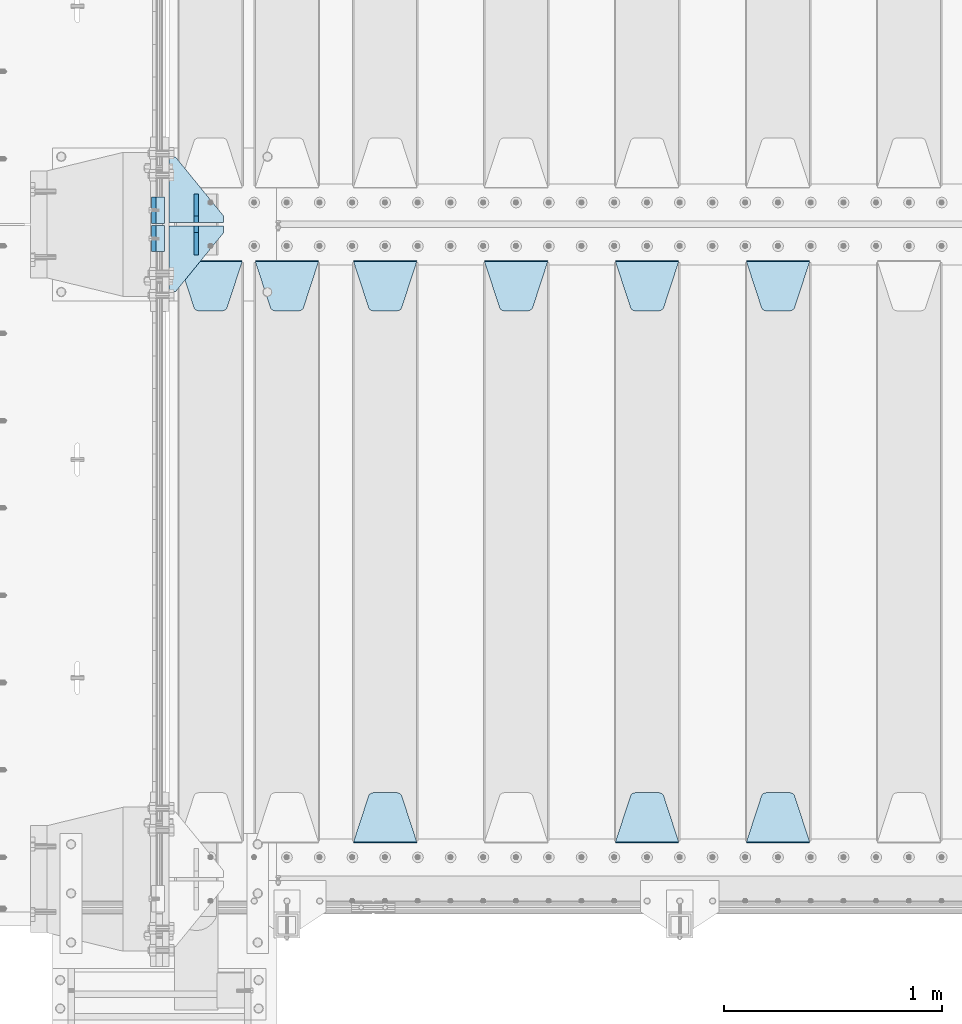
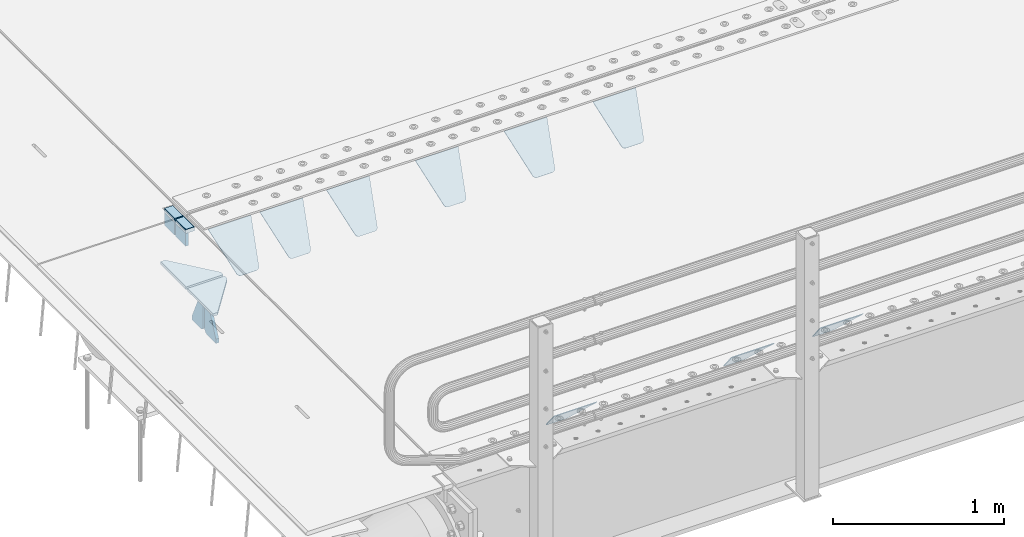
# One storey, part 175 of 219: 17 plates.
"""IFC2X3 building model written with IfcOpenShell, lengths in millimetres."""

from ifc_helpers import new_model, si_unit, frame, origin_with_axes, place, context, subcontext, project, spatial, faceted_brep, material, type_object, element, save


model = new_model("IFC2X3")

# Units and contexts
model_context = context("Model", 3, precision=1e-05, world=origin_with_axes())
body_context = subcontext(model_context, "Body", "Model", "MODEL_VIEW")
ifc_project = project(units=[si_unit("LENGTHUNIT", "METRE", prefix="MILLI"), si_unit("AREAUNIT", "SQUARE_METRE"), si_unit("VOLUMEUNIT", "CUBIC_METRE"), si_unit("MASSUNIT", "GRAM", prefix="KILO"), si_unit("TIMEUNIT", "SECOND"), si_unit("PLANEANGLEUNIT", "RADIAN"), si_unit("SOLIDANGLEUNIT", "STERADIAN"), si_unit("THERMODYNAMICTEMPERATUREUNIT", "DEGREE_CELSIUS"), si_unit("LUMINOUSINTENSITYUNIT", "LUMEN")], contexts=[model_context])

# Site, building, storey
site_placement = place(None, origin_with_axes())
site = spatial("IfcSite", under=ifc_project, at=site_placement, CompositionType="ELEMENT")
building_placement = place(site_placement, origin_with_axes())
building = spatial("IfcBuilding", under=site, at=building_placement, Name="Standard", CompositionType="ELEMENT")
storey_placement = place(building_placement, origin_with_axes())
storey = spatial("IfcBuildingStorey", under=building, at=storey_placement, Name="Undefined", CompositionType="ELEMENT", Elevation=0.0)

# Plates
ifc_material_1 = material()
plate_type_1 = type_object("IfcPlateType", PredefinedType="NOTDEFINED")
plate_1_placement = place(storey_placement, frame((-10.000000000067, 26935.0000000001, -16.0000945328547), z_axis=(-1.0, 0.0, 0.0), x_axis=(0.0, 0.0, 1.0)))
element("IfcPlate", 1, at=plate_1_placement, inside=storey, type_object=plate_type_1, material=ifc_material_1, context=body_context, shape_type="Brep", body=[
    faceted_brep([(0.0, -60.0, 0.0), (2.49929144047201e-09, -60.0, 60.0), (2.49929144047201e-09, 60.0000000000036, 60.0), (0.0, 60.0000000000036, 0.0), (25.0146748218828, -60.0, 60.0), (25.0146748218828, 60.0, 60.0), (26.5597449794466, -60.0, 59.7552873949117), (26.5597449794466, 60.0000000000036, 59.7552873949117), (27.9535758796897, -59.9999999999964, 59.0451032832824), (27.9535758796897, 60.0000000000036, 59.0451032832824), (29.0597323263517, -60.0, 57.9389640667317), (29.0597323263517, 60.0, 57.9389640667317), (29.7699381491534, -59.9999999999964, 56.5451442289687), (29.7699381491534, 60.0, 56.5451442289687), (30.0146748212763, -60.0, 55.0000778834025), (30.0146748212762, 60.0, 55.0000778834025), (30.0154536553013, -59.9999999999964, 5.00007788340855), (30.0154536553013, 60.0000000000036, 5.00007788340855), (29.7707554908505, -60.0, 3.45497428546548), (29.7707554908505, 60.0, 3.45497428546548), (29.0605660948355, -60.0, 2.06111154407017), (29.0605660948355, 60.0, 2.06111154407017), (27.9544051209123, -59.9999999999964, 0.954933339696428), (27.9544051209123, 60.0000000000036, 0.954933339696428), (26.5605534420796, -59.9999999999964, 0.244722232012666), (26.5605534420796, 60.0000000000036, 0.244722232012666), (25.0154536559091, -60.0, 6.05382410867605e-12), (25.0154536559091, 60.0, 6.05382410867605e-12)], [[[0, 1, 2, 3]], [[1, 4, 5, 2]], [[4, 6, 7, 5]], [[6, 8, 9, 7]], [[8, 10, 11, 9]], [[10, 12, 13, 11]], [[12, 14, 15, 13]], [[14, 16, 17, 15]], [[16, 18, 19, 17]], [[18, 20, 21, 19]], [[20, 22, 23, 21]], [[22, 24, 25, 23]], [[24, 26, 27, 25]], [[26, 0, 3, 27]], [[5, 7, 9, 11, 13, 15, 17, 19, 21, 23, 25, 27, 3, 2]], [[26, 24, 22, 20, 18, 16, 14, 12, 10, 8, 6, 4, 1, 0]]]),
])
plate_2_placement = place(storey_placement, frame((-10.0000000600267, 27065.0000004521, -16.0145962164398), z_axis=(-1.0, 0.0, 0.0), x_axis=(0.0, -4.95099997756316e-06, 0.999999999987744)))
element("IfcPlate", 2, at=plate_2_placement, inside=storey, type_object=plate_type_1, material=ifc_material_1, context=body_context, shape_type="Brep", body=[
    faceted_brep([(0.0, -60.0, 0.0), (-0.000933120085687023, -60.0000000000036, 60.0), (-0.000933120085687023, 59.9999999999964, 60.0), (0.0, 60.0000000000036, 0.0), (24.9991450303709, -60.0, 60.0), (24.9991450303709, 59.9999999999964, 60.0), (26.544215218168, -60.0000000000036, 59.7552873850884), (26.544215218168, 60.0, 59.7552873850884), (27.9380461396139, -60.0000000000036, 59.0451032459123), (27.9380461396139, 60.0, 59.0451032459123), (29.0442025908961, -60.0000000000036, 57.9389639895784), (29.0442025908961, 60.0, 57.9389639895784), (29.7544083969366, -60.0, 56.5451441080361), (29.7544083969366, 60.0000000000036, 56.5451441080361), (29.9991450297669, -60.0000000000036, 55.0000777244568), (29.9991450297669, 60.0, 55.0000777244568), (29.999922274335, -60.0, 5.00007772445704), (29.999922274335, 60.0, 5.00007772445704), (29.7552240705896, -60.0000000000036, 3.45497416452589), (29.7552240705896, 60.0, 3.45497416452589), (29.0450346578116, -60.0, 2.06111146690959), (29.0450346578116, 59.9999999999964, 2.06111146690959), (27.9388736885072, -60.0, 0.954933302319514), (27.9388736885072, 59.9999999999964, 0.954933302319514), (26.5450220308766, -60.0000000000036, 0.244722222183089), (26.5450220308766, 60.0, 0.244722222183089), (24.9999222749392, -60.0, 2.64677169070637e-13), (24.9999222749392, 60.0, 2.66453525910038e-13)], [[[0, 1, 2, 3]], [[1, 4, 5, 2]], [[4, 6, 7, 5]], [[6, 8, 9, 7]], [[8, 10, 11, 9]], [[10, 12, 13, 11]], [[12, 14, 15, 13]], [[14, 16, 17, 15]], [[16, 18, 19, 17]], [[18, 20, 21, 19]], [[20, 22, 23, 21]], [[22, 24, 25, 23]], [[24, 26, 27, 25]], [[26, 0, 3, 27]], [[5, 7, 9, 11, 13, 15, 17, 19, 21, 23, 25, 27, 3, 2]], [[26, 24, 22, 20, 18, 16, 14, 12, 10, 8, 6, 4, 1, 0]]]),
])
ifc_material_2 = material(Name="STEEL/S355N")
plate_type_2 = type_object("IfcPlateType", PredefinedType="NOTDEFINED")
plate_3_placement = place(storey_placement, frame((-60.0000000000706, 26995.0000855345, -105.984429072951), z_axis=(0.0, -1.0, 0.0), x_axis=(0.0, 0.0, 1.0)))
element("IfcPlate", 3, at=plate_3_placement, inside=storey, type_object=plate_type_2, material=ifc_material_2, context=body_context, shape_type="Brep", body=[
    faceted_brep([(0.0, -10.0, 0.0), (4.30816271546064e-10, -10.0, 120.000000000004), (4.30816271546064e-10, 10.0, 120.000000000004), (0.0, 10.0, 0.0), (89.9845046997066, -10.0, 120.0), (89.9845046997066, 10.0, 120.0), (89.9843902587891, -10.0, 6.18456397205591e-11), (89.9843902587891, 10.0, 6.18456397205591e-11)], [[[0, 1, 2, 3]], [[1, 4, 5, 2]], [[4, 6, 7, 5]], [[6, 0, 3, 7]], [[5, 7, 3, 2]], [[6, 4, 1, 0]]]),
])
plate_4_placement = place(storey_placement, frame((-60.0, 27125.000446002, -106.014921246643), z_axis=(0.0, -0.999999999987744, -4.95099999993769e-06), x_axis=(0.0, -4.95099997756316e-06, 0.999999999987744)))
element("IfcPlate", 4, at=plate_4_placement, inside=storey, type_object=plate_type_2, material=ifc_material_2, context=body_context, shape_type="Brep", body=[
    faceted_brep([(0.0, -10.0, 0.0), (4.30816271546064e-10, -10.0, 120.000000000004), (4.30816271546064e-10, 10.0, 120.000000000004), (0.0, 10.0, 0.0), (89.9999999999979, -10.0, 120.000000000004), (89.9999999999979, 10.0, 120.000000000004), (90.0, -10.0, 1.09139364212751e-11), (90.0, 10.0, 1.09139364212751e-11)], [[[0, 1, 2, 3]], [[1, 4, 5, 2]], [[4, 6, 7, 5]], [[6, 0, 3, 7]], [[5, 7, 3, 2]], [[6, 4, 1, 0]]]),
])
plate_type_3 = type_object("IfcPlateType", PredefinedType="NOTDEFINED")
plate_5_placement = place(storey_placement, frame((2655.0, 26831.767766956, -1.76776695296758), z_axis=(0.0, -0.707106781186547, -0.707106781186548), x_axis=(1.0, 0.0, 0.0)))
element("IfcPlate", 5, at=plate_5_placement, inside=storey, type_object=plate_type_3, material=ifc_material_2, context=body_context, shape_type="Brep", body=[
    faceted_brep([(0.0, -2.5, 0.0), (69.345504679477, -2.5, 300.171731424834), (69.345504679477, 2.49999999999636, 300.171731424831), (0.0, 2.5, 0.0), (70.9274061199576, -2.50000000000364, 304.8974424154), (70.9274061199576, 2.49999999999636, 304.8974424154), (73.3818627772307, -2.50000000000364, 309.234538108532), (73.3818627772307, 2.49999999999636, 309.234538108532), (76.6187032999569, -2.50000000000364, 313.023683126106), (76.6187032999569, 2.49999999999636, 313.023683126106), (80.5190132704993, -2.50000000000364, 316.125672595372), (80.5190132704993, 2.49999999999636, 316.125672595372), (84.9395038596831, -2.50000000000364, 318.426546230476), (84.9395038596831, 2.5, 318.426546230479), (89.7177759439237, -2.50000000000364, 319.841774983277), (89.7177759439237, 2.5, 319.841774983281), (94.6782862926502, -2.50000000000364, 320.319366455078), (94.6782862926502, 2.49999999999636, 320.319366455078), (195.32171370735, -2.50000000000364, 320.319366455078), (195.32171370735, 2.49999999999636, 320.319366455078), (200.282224056076, -2.50000000000364, 319.841774983277), (200.282224056076, 2.5, 319.841774983281), (205.060496140317, -2.50000000000364, 318.426546230476), (205.060496140317, 2.49999999999636, 318.426546230476), (209.480986729501, -2.50000000000364, 316.125672595372), (209.480986729501, 2.49999999999636, 316.125672595372), (213.381296700043, -2.50000000000364, 313.023683126106), (213.381296700043, 2.49999999999272, 313.023683126106), (216.618137222769, -2.50000000000364, 309.234538108529), (216.618137222769, 2.49999999999636, 309.234538108525), (219.072593880042, -2.50000000000364, 304.8974424154), (219.072593880042, 2.49999999999636, 304.8974424154), (220.654495320523, -2.5, 300.171731424834), (220.654495320523, 2.49999999999636, 300.171731424831), (290.0, -2.50000000000364, 3.63797880709171e-12), (290.0, 2.49999999999636, 0.0)], [[[0, 1, 2, 3]], [[1, 4, 5, 2]], [[4, 6, 7, 5]], [[6, 8, 9, 7]], [[8, 10, 11, 9]], [[10, 12, 13, 11]], [[12, 14, 15, 13]], [[14, 16, 17, 15]], [[16, 18, 19, 17]], [[18, 20, 21, 19]], [[20, 22, 23, 21]], [[22, 24, 25, 23]], [[24, 26, 27, 25]], [[26, 28, 29, 27]], [[28, 30, 31, 29]], [[30, 32, 33, 31]], [[32, 34, 35, 33]], [[34, 0, 3, 35]], [[5, 7, 9, 11, 13, 15, 17, 19, 21, 23, 25, 27, 29, 31, 33, 35, 3, 2]], [[34, 32, 30, 28, 26, 24, 22, 20, 18, 16, 14, 12, 10, 8, 6, 4, 1, 0]]]),
])
plate_6_placement = place(storey_placement, frame((2945.0, 24168.232233047, -1.76776695296758), z_axis=(0.0, 0.707106781186547, -0.707106781186548), x_axis=(-1.0, 0.0, 0.0)))
element("IfcPlate", 6, at=plate_6_placement, inside=storey, type_object=plate_type_3, material=ifc_material_2, context=body_context, shape_type="Brep", body=[
    faceted_brep([(0.0, -2.5, 0.0), (69.345504679477, -2.5, 300.171731424834), (69.345504679477, 2.49999999999636, 300.171731424831), (0.0, 2.5, 0.0), (70.9274061199576, -2.50000000000364, 304.8974424154), (70.9274061199576, 2.49999999999636, 304.8974424154), (73.3818627772307, -2.50000000000364, 309.234538108532), (73.3818627772307, 2.49999999999636, 309.234538108532), (76.6187032999569, -2.50000000000364, 313.023683126106), (76.6187032999569, 2.49999999999636, 313.023683126106), (80.5190132704993, -2.50000000000364, 316.125672595372), (80.5190132704993, 2.49999999999636, 316.125672595372), (84.9395038596831, -2.50000000000364, 318.426546230476), (84.9395038596831, 2.5, 318.426546230479), (89.7177759439237, -2.50000000000364, 319.841774983277), (89.7177759439237, 2.5, 319.841774983281), (94.6782862926502, -2.50000000000364, 320.319366455078), (94.6782862926502, 2.49999999999636, 320.319366455078), (195.32171370735, -2.50000000000364, 320.319366455078), (195.32171370735, 2.49999999999636, 320.319366455078), (200.282224056076, -2.50000000000364, 319.841774983277), (200.282224056076, 2.5, 319.841774983281), (205.060496140317, -2.50000000000364, 318.426546230476), (205.060496140317, 2.49999999999636, 318.426546230476), (209.480986729501, -2.50000000000364, 316.125672595372), (209.480986729501, 2.49999999999636, 316.125672595372), (213.381296700043, -2.50000000000364, 313.023683126106), (213.381296700043, 2.49999999999272, 313.023683126106), (216.618137222769, -2.50000000000364, 309.234538108529), (216.618137222769, 2.49999999999636, 309.234538108525), (219.072593880042, -2.50000000000364, 304.8974424154), (219.072593880042, 2.49999999999636, 304.8974424154), (220.654495320523, -2.5, 300.171731424834), (220.654495320523, 2.49999999999636, 300.171731424831), (290.0, -2.50000000000364, 3.63797880709171e-12), (290.0, 2.49999999999636, 0.0)], [[[0, 1, 2, 3]], [[1, 4, 5, 2]], [[4, 6, 7, 5]], [[6, 8, 9, 7]], [[8, 10, 11, 9]], [[10, 12, 13, 11]], [[12, 14, 15, 13]], [[14, 16, 17, 15]], [[16, 18, 19, 17]], [[18, 20, 21, 19]], [[20, 22, 23, 21]], [[22, 24, 25, 23]], [[24, 26, 27, 25]], [[26, 28, 29, 27]], [[28, 30, 31, 29]], [[30, 32, 33, 31]], [[32, 34, 35, 33]], [[34, 0, 3, 35]], [[5, 7, 9, 11, 13, 15, 17, 19, 21, 23, 25, 27, 29, 31, 33, 35, 3, 2]], [[34, 32, 30, 28, 26, 24, 22, 20, 18, 16, 14, 12, 10, 8, 6, 4, 1, 0]]]),
])
plate_7_placement = place(storey_placement, frame((2055.0, 26831.767766956, -1.76776695296758), z_axis=(0.0, -0.707106781186547, -0.707106781186548), x_axis=(1.0, 0.0, 0.0)))
element("IfcPlate", 7, at=plate_7_placement, inside=storey, type_object=plate_type_3, material=ifc_material_2, context=body_context, shape_type="Brep", body=[
    faceted_brep([(0.0, -2.5, 0.0), (69.345504679477, -2.5, 300.171731424834), (69.345504679477, 2.49999999999636, 300.171731424831), (0.0, 2.5, 0.0), (70.9274061199576, -2.50000000000364, 304.8974424154), (70.9274061199576, 2.49999999999636, 304.8974424154), (73.3818627772307, -2.50000000000364, 309.234538108532), (73.3818627772307, 2.49999999999636, 309.234538108532), (76.6187032999569, -2.50000000000364, 313.023683126106), (76.6187032999569, 2.49999999999636, 313.023683126106), (80.5190132704993, -2.50000000000364, 316.125672595372), (80.5190132704993, 2.49999999999636, 316.125672595372), (84.9395038596831, -2.50000000000364, 318.426546230476), (84.9395038596831, 2.5, 318.426546230479), (89.7177759439237, -2.50000000000364, 319.841774983277), (89.7177759439237, 2.5, 319.841774983281), (94.6782862926502, -2.50000000000364, 320.319366455078), (94.6782862926502, 2.49999999999636, 320.319366455078), (195.32171370735, -2.50000000000364, 320.319366455078), (195.32171370735, 2.49999999999636, 320.319366455078), (200.282224056076, -2.50000000000364, 319.841774983277), (200.282224056076, 2.5, 319.841774983281), (205.060496140317, -2.50000000000364, 318.426546230476), (205.060496140317, 2.49999999999636, 318.426546230476), (209.480986729501, -2.50000000000364, 316.125672595372), (209.480986729501, 2.49999999999636, 316.125672595372), (213.381296700043, -2.50000000000364, 313.023683126106), (213.381296700043, 2.49999999999272, 313.023683126106), (216.618137222769, -2.50000000000364, 309.234538108529), (216.618137222769, 2.49999999999636, 309.234538108525), (219.072593880042, -2.50000000000364, 304.8974424154), (219.072593880042, 2.49999999999636, 304.8974424154), (220.654495320523, -2.5, 300.171731424834), (220.654495320523, 2.49999999999636, 300.171731424831), (290.0, -2.50000000000364, 3.63797880709171e-12), (290.0, 2.49999999999636, 0.0)], [[[0, 1, 2, 3]], [[1, 4, 5, 2]], [[4, 6, 7, 5]], [[6, 8, 9, 7]], [[8, 10, 11, 9]], [[10, 12, 13, 11]], [[12, 14, 15, 13]], [[14, 16, 17, 15]], [[16, 18, 19, 17]], [[18, 20, 21, 19]], [[20, 22, 23, 21]], [[22, 24, 25, 23]], [[24, 26, 27, 25]], [[26, 28, 29, 27]], [[28, 30, 31, 29]], [[30, 32, 33, 31]], [[32, 34, 35, 33]], [[34, 0, 3, 35]], [[5, 7, 9, 11, 13, 15, 17, 19, 21, 23, 25, 27, 29, 31, 33, 35, 3, 2]], [[34, 32, 30, 28, 26, 24, 22, 20, 18, 16, 14, 12, 10, 8, 6, 4, 1, 0]]]),
])
plate_8_placement = place(storey_placement, frame((2345.0, 24168.232233047, -1.76776695296758), z_axis=(0.0, 0.707106781186547, -0.707106781186548), x_axis=(-1.0, 0.0, 0.0)))
element("IfcPlate", 8, at=plate_8_placement, inside=storey, type_object=plate_type_3, material=ifc_material_2, context=body_context, shape_type="Brep", body=[
    faceted_brep([(0.0, -2.5, 0.0), (69.345504679477, -2.5, 300.171731424834), (69.345504679477, 2.49999999999636, 300.171731424831), (0.0, 2.5, 0.0), (70.9274061199576, -2.50000000000364, 304.8974424154), (70.9274061199576, 2.49999999999636, 304.8974424154), (73.3818627772307, -2.50000000000364, 309.234538108532), (73.3818627772307, 2.49999999999636, 309.234538108532), (76.6187032999569, -2.50000000000364, 313.023683126106), (76.6187032999569, 2.49999999999636, 313.023683126106), (80.5190132704993, -2.50000000000364, 316.125672595372), (80.5190132704993, 2.49999999999636, 316.125672595372), (84.9395038596831, -2.50000000000364, 318.426546230476), (84.9395038596831, 2.5, 318.426546230479), (89.7177759439237, -2.50000000000364, 319.841774983277), (89.7177759439237, 2.5, 319.841774983281), (94.6782862926502, -2.50000000000364, 320.319366455078), (94.6782862926502, 2.49999999999636, 320.319366455078), (195.32171370735, -2.50000000000364, 320.319366455078), (195.32171370735, 2.49999999999636, 320.319366455078), (200.282224056076, -2.50000000000364, 319.841774983277), (200.282224056076, 2.5, 319.841774983281), (205.060496140317, -2.50000000000364, 318.426546230476), (205.060496140317, 2.49999999999636, 318.426546230476), (209.480986729501, -2.50000000000364, 316.125672595372), (209.480986729501, 2.49999999999636, 316.125672595372), (213.381296700043, -2.50000000000364, 313.023683126106), (213.381296700043, 2.49999999999272, 313.023683126106), (216.618137222769, -2.50000000000364, 309.234538108529), (216.618137222769, 2.49999999999636, 309.234538108525), (219.072593880042, -2.50000000000364, 304.8974424154), (219.072593880042, 2.49999999999636, 304.8974424154), (220.654495320523, -2.5, 300.171731424834), (220.654495320523, 2.49999999999636, 300.171731424831), (290.0, -2.50000000000364, 3.63797880709171e-12), (290.0, 2.49999999999636, 0.0)], [[[0, 1, 2, 3]], [[1, 4, 5, 2]], [[4, 6, 7, 5]], [[6, 8, 9, 7]], [[8, 10, 11, 9]], [[10, 12, 13, 11]], [[12, 14, 15, 13]], [[14, 16, 17, 15]], [[16, 18, 19, 17]], [[18, 20, 21, 19]], [[20, 22, 23, 21]], [[22, 24, 25, 23]], [[24, 26, 27, 25]], [[26, 28, 29, 27]], [[28, 30, 31, 29]], [[30, 32, 33, 31]], [[32, 34, 35, 33]], [[34, 0, 3, 35]], [[5, 7, 9, 11, 13, 15, 17, 19, 21, 23, 25, 27, 29, 31, 33, 35, 3, 2]], [[34, 32, 30, 28, 26, 24, 22, 20, 18, 16, 14, 12, 10, 8, 6, 4, 1, 0]]]),
])
plate_9_placement = place(storey_placement, frame((1455.0, 26831.767766956, -1.76776695296758), z_axis=(0.0, -0.707106781186547, -0.707106781186548), x_axis=(1.0, 0.0, 0.0)))
element("IfcPlate", 9, at=plate_9_placement, inside=storey, type_object=plate_type_3, material=ifc_material_2, context=body_context, shape_type="Brep", body=[
    faceted_brep([(0.0, -2.5, 0.0), (69.345504679477, -2.5, 300.171731424834), (69.345504679477, 2.49999999999636, 300.171731424831), (0.0, 2.5, 0.0), (70.9274061199576, -2.50000000000364, 304.8974424154), (70.9274061199576, 2.49999999999636, 304.8974424154), (73.3818627772307, -2.50000000000364, 309.234538108532), (73.3818627772307, 2.49999999999636, 309.234538108532), (76.6187032999569, -2.50000000000364, 313.023683126106), (76.6187032999569, 2.49999999999636, 313.023683126106), (80.5190132704993, -2.50000000000364, 316.125672595372), (80.5190132704993, 2.49999999999636, 316.125672595372), (84.9395038596831, -2.50000000000364, 318.426546230476), (84.9395038596831, 2.5, 318.426546230479), (89.7177759439237, -2.50000000000364, 319.841774983277), (89.7177759439237, 2.5, 319.841774983281), (94.6782862926502, -2.50000000000364, 320.319366455078), (94.6782862926502, 2.49999999999636, 320.319366455078), (195.32171370735, -2.50000000000364, 320.319366455078), (195.32171370735, 2.49999999999636, 320.319366455078), (200.282224056076, -2.50000000000364, 319.841774983277), (200.282224056076, 2.5, 319.841774983281), (205.060496140317, -2.50000000000364, 318.426546230476), (205.060496140317, 2.49999999999636, 318.426546230476), (209.480986729501, -2.50000000000364, 316.125672595372), (209.480986729501, 2.49999999999636, 316.125672595372), (213.381296700043, -2.50000000000364, 313.023683126106), (213.381296700043, 2.49999999999272, 313.023683126106), (216.618137222769, -2.50000000000364, 309.234538108529), (216.618137222769, 2.49999999999636, 309.234538108525), (219.072593880042, -2.50000000000364, 304.8974424154), (219.072593880042, 2.49999999999636, 304.8974424154), (220.654495320523, -2.5, 300.171731424834), (220.654495320523, 2.49999999999636, 300.171731424831), (290.0, -2.50000000000364, 3.63797880709171e-12), (290.0, 2.49999999999636, 0.0)], [[[0, 1, 2, 3]], [[1, 4, 5, 2]], [[4, 6, 7, 5]], [[6, 8, 9, 7]], [[8, 10, 11, 9]], [[10, 12, 13, 11]], [[12, 14, 15, 13]], [[14, 16, 17, 15]], [[16, 18, 19, 17]], [[18, 20, 21, 19]], [[20, 22, 23, 21]], [[22, 24, 25, 23]], [[24, 26, 27, 25]], [[26, 28, 29, 27]], [[28, 30, 31, 29]], [[30, 32, 33, 31]], [[32, 34, 35, 33]], [[34, 0, 3, 35]], [[5, 7, 9, 11, 13, 15, 17, 19, 21, 23, 25, 27, 29, 31, 33, 35, 3, 2]], [[34, 32, 30, 28, 26, 24, 22, 20, 18, 16, 14, 12, 10, 8, 6, 4, 1, 0]]]),
])
plate_10_placement = place(storey_placement, frame((855.0, 26831.767766956, -1.76776695296758), z_axis=(0.0, -0.707106781186547, -0.707106781186548), x_axis=(1.0, 0.0, 0.0)))
element("IfcPlate", 10, at=plate_10_placement, inside=storey, type_object=plate_type_3, material=ifc_material_2, context=body_context, shape_type="Brep", body=[
    faceted_brep([(0.0, -2.5, 0.0), (69.345504679477, -2.5, 300.171731424834), (69.345504679477, 2.49999999999636, 300.171731424831), (0.0, 2.5, 0.0), (70.9274061199576, -2.50000000000364, 304.8974424154), (70.9274061199576, 2.49999999999636, 304.8974424154), (73.3818627772307, -2.50000000000364, 309.234538108532), (73.3818627772307, 2.49999999999636, 309.234538108532), (76.6187032999569, -2.50000000000364, 313.023683126106), (76.6187032999569, 2.49999999999636, 313.023683126106), (80.5190132704993, -2.50000000000364, 316.125672595372), (80.5190132704993, 2.49999999999636, 316.125672595372), (84.9395038596831, -2.50000000000364, 318.426546230476), (84.9395038596831, 2.5, 318.426546230479), (89.7177759439237, -2.50000000000364, 319.841774983277), (89.7177759439237, 2.5, 319.841774983281), (94.6782862926502, -2.50000000000364, 320.319366455078), (94.6782862926502, 2.49999999999636, 320.319366455078), (195.32171370735, -2.50000000000364, 320.319366455078), (195.32171370735, 2.49999999999636, 320.319366455078), (200.282224056076, -2.50000000000364, 319.841774983277), (200.282224056076, 2.5, 319.841774983281), (205.060496140317, -2.50000000000364, 318.426546230476), (205.060496140317, 2.49999999999636, 318.426546230476), (209.480986729501, -2.50000000000364, 316.125672595372), (209.480986729501, 2.49999999999636, 316.125672595372), (213.381296700043, -2.50000000000364, 313.023683126106), (213.381296700043, 2.49999999999272, 313.023683126106), (216.618137222769, -2.50000000000364, 309.234538108529), (216.618137222769, 2.49999999999636, 309.234538108525), (219.072593880042, -2.50000000000364, 304.8974424154), (219.072593880042, 2.49999999999636, 304.8974424154), (220.654495320523, -2.5, 300.171731424834), (220.654495320523, 2.49999999999636, 300.171731424831), (290.0, -2.50000000000364, 3.63797880709171e-12), (290.0, 2.49999999999636, 0.0)], [[[0, 1, 2, 3]], [[1, 4, 5, 2]], [[4, 6, 7, 5]], [[6, 8, 9, 7]], [[8, 10, 11, 9]], [[10, 12, 13, 11]], [[12, 14, 15, 13]], [[14, 16, 17, 15]], [[16, 18, 19, 17]], [[18, 20, 21, 19]], [[20, 22, 23, 21]], [[22, 24, 25, 23]], [[24, 26, 27, 25]], [[26, 28, 29, 27]], [[28, 30, 31, 29]], [[30, 32, 33, 31]], [[32, 34, 35, 33]], [[34, 0, 3, 35]], [[5, 7, 9, 11, 13, 15, 17, 19, 21, 23, 25, 27, 29, 31, 33, 35, 3, 2]], [[34, 32, 30, 28, 26, 24, 22, 20, 18, 16, 14, 12, 10, 8, 6, 4, 1, 0]]]),
])
plate_11_placement = place(storey_placement, frame((1145.0, 24168.232233047, -1.76776695296758), z_axis=(0.0, 0.707106781186547, -0.707106781186548), x_axis=(-1.0, 0.0, 0.0)))
element("IfcPlate", 11, at=plate_11_placement, inside=storey, type_object=plate_type_3, material=ifc_material_2, context=body_context, shape_type="Brep", body=[
    faceted_brep([(0.0, -2.5, 0.0), (69.345504679477, -2.5, 300.171731424834), (69.345504679477, 2.49999999999636, 300.171731424831), (0.0, 2.5, 0.0), (70.9274061199576, -2.50000000000364, 304.8974424154), (70.9274061199576, 2.49999999999636, 304.8974424154), (73.3818627772307, -2.50000000000364, 309.234538108532), (73.3818627772307, 2.49999999999636, 309.234538108532), (76.6187032999569, -2.50000000000364, 313.023683126106), (76.6187032999569, 2.49999999999636, 313.023683126106), (80.5190132704993, -2.50000000000364, 316.125672595372), (80.5190132704993, 2.49999999999636, 316.125672595372), (84.9395038596831, -2.50000000000364, 318.426546230476), (84.9395038596831, 2.5, 318.426546230479), (89.7177759439237, -2.50000000000364, 319.841774983277), (89.7177759439237, 2.5, 319.841774983281), (94.6782862926502, -2.50000000000364, 320.319366455078), (94.6782862926502, 2.49999999999636, 320.319366455078), (195.32171370735, -2.50000000000364, 320.319366455078), (195.32171370735, 2.49999999999636, 320.319366455078), (200.282224056076, -2.50000000000364, 319.841774983277), (200.282224056076, 2.5, 319.841774983281), (205.060496140317, -2.50000000000364, 318.426546230476), (205.060496140317, 2.49999999999636, 318.426546230476), (209.480986729501, -2.50000000000364, 316.125672595372), (209.480986729501, 2.49999999999636, 316.125672595372), (213.381296700043, -2.50000000000364, 313.023683126106), (213.381296700043, 2.49999999999272, 313.023683126106), (216.618137222769, -2.50000000000364, 309.234538108529), (216.618137222769, 2.49999999999636, 309.234538108525), (219.072593880042, -2.50000000000364, 304.8974424154), (219.072593880042, 2.49999999999636, 304.8974424154), (220.654495320523, -2.5, 300.171731424834), (220.654495320523, 2.49999999999636, 300.171731424831), (290.0, -2.50000000000364, 3.63797880709171e-12), (290.0, 2.49999999999636, 0.0)], [[[0, 1, 2, 3]], [[1, 4, 5, 2]], [[4, 6, 7, 5]], [[6, 8, 9, 7]], [[8, 10, 11, 9]], [[10, 12, 13, 11]], [[12, 14, 15, 13]], [[14, 16, 17, 15]], [[16, 18, 19, 17]], [[18, 20, 21, 19]], [[20, 22, 23, 21]], [[22, 24, 25, 23]], [[24, 26, 27, 25]], [[26, 28, 29, 27]], [[28, 30, 31, 29]], [[30, 32, 33, 31]], [[32, 34, 35, 33]], [[34, 0, 3, 35]], [[5, 7, 9, 11, 13, 15, 17, 19, 21, 23, 25, 27, 29, 31, 33, 35, 3, 2]], [[34, 32, 30, 28, 26, 24, 22, 20, 18, 16, 14, 12, 10, 8, 6, 4, 1, 0]]]),
])
plate_12_placement = place(storey_placement, frame((405.0, 26831.767766956, -1.76776695296758), z_axis=(0.0, -0.707106781186547, -0.707106781186548), x_axis=(1.0, 0.0, 0.0)))
element("IfcPlate", 12, at=plate_12_placement, inside=storey, type_object=plate_type_3, material=ifc_material_2, context=body_context, shape_type="Brep", body=[
    faceted_brep([(0.0, -2.5, 0.0), (69.345504679477, -2.5, 300.171731424834), (69.345504679477, 2.49999999999636, 300.171731424831), (0.0, 2.5, 0.0), (70.9274061199576, -2.50000000000364, 304.8974424154), (70.9274061199576, 2.49999999999636, 304.8974424154), (73.3818627772307, -2.50000000000364, 309.234538108532), (73.3818627772307, 2.49999999999636, 309.234538108532), (76.6187032999569, -2.50000000000364, 313.023683126106), (76.6187032999569, 2.49999999999636, 313.023683126106), (80.5190132704993, -2.50000000000364, 316.125672595372), (80.5190132704993, 2.49999999999636, 316.125672595372), (84.9395038596831, -2.50000000000364, 318.426546230476), (84.9395038596831, 2.5, 318.426546230479), (89.7177759439237, -2.50000000000364, 319.841774983277), (89.7177759439237, 2.5, 319.841774983281), (94.6782862926502, -2.50000000000364, 320.319366455078), (94.6782862926502, 2.49999999999636, 320.319366455078), (195.32171370735, -2.50000000000364, 320.319366455078), (195.32171370735, 2.49999999999636, 320.319366455078), (200.282224056076, -2.50000000000364, 319.841774983277), (200.282224056076, 2.5, 319.841774983281), (205.060496140317, -2.50000000000364, 318.426546230476), (205.060496140317, 2.49999999999636, 318.426546230476), (209.480986729501, -2.50000000000364, 316.125672595372), (209.480986729501, 2.49999999999636, 316.125672595372), (213.381296700043, -2.50000000000364, 313.023683126106), (213.381296700043, 2.49999999999272, 313.023683126106), (216.618137222769, -2.50000000000364, 309.234538108529), (216.618137222769, 2.49999999999636, 309.234538108525), (219.072593880042, -2.50000000000364, 304.8974424154), (219.072593880042, 2.49999999999636, 304.8974424154), (220.654495320523, -2.5, 300.171731424834), (220.654495320523, 2.49999999999636, 300.171731424831), (290.0, -2.50000000000364, 3.63797880709171e-12), (290.0, 2.49999999999636, 0.0)], [[[0, 1, 2, 3]], [[1, 4, 5, 2]], [[4, 6, 7, 5]], [[6, 8, 9, 7]], [[8, 10, 11, 9]], [[10, 12, 13, 11]], [[12, 14, 15, 13]], [[14, 16, 17, 15]], [[16, 18, 19, 17]], [[18, 20, 21, 19]], [[20, 22, 23, 21]], [[22, 24, 25, 23]], [[24, 26, 27, 25]], [[26, 28, 29, 27]], [[28, 30, 31, 29]], [[30, 32, 33, 31]], [[32, 34, 35, 33]], [[34, 0, 3, 35]], [[5, 7, 9, 11, 13, 15, 17, 19, 21, 23, 25, 27, 29, 31, 33, 35, 3, 2]], [[34, 32, 30, 28, 26, 24, 22, 20, 18, 16, 14, 12, 10, 8, 6, 4, 1, 0]]]),
])
plate_13_placement = place(storey_placement, frame((55.0, 26831.767766956, -1.76776695296758), z_axis=(0.0, -0.707106781186547, -0.707106781186548), x_axis=(1.0, 0.0, 0.0)))
element("IfcPlate", 13, at=plate_13_placement, inside=storey, type_object=plate_type_3, material=ifc_material_2, context=body_context, shape_type="Brep", body=[
    faceted_brep([(0.0, -2.5, 0.0), (69.345504679477, -2.5, 300.171731424834), (69.345504679477, 2.49999999999636, 300.171731424831), (0.0, 2.5, 0.0), (70.9274061199576, -2.50000000000364, 304.8974424154), (70.9274061199576, 2.49999999999636, 304.8974424154), (73.3818627772307, -2.50000000000364, 309.234538108532), (73.3818627772307, 2.49999999999636, 309.234538108532), (76.6187032999569, -2.50000000000364, 313.023683126106), (76.6187032999569, 2.49999999999636, 313.023683126106), (80.5190132704993, -2.50000000000364, 316.125672595372), (80.5190132704993, 2.49999999999636, 316.125672595372), (84.9395038596831, -2.50000000000364, 318.426546230476), (84.9395038596831, 2.5, 318.426546230479), (89.7177759439237, -2.50000000000364, 319.841774983277), (89.7177759439237, 2.5, 319.841774983281), (94.6782862926502, -2.50000000000364, 320.319366455078), (94.6782862926502, 2.49999999999636, 320.319366455078), (195.32171370735, -2.50000000000364, 320.319366455078), (195.32171370735, 2.49999999999636, 320.319366455078), (200.282224056076, -2.50000000000364, 319.841774983277), (200.282224056076, 2.5, 319.841774983281), (205.060496140317, -2.50000000000364, 318.426546230476), (205.060496140317, 2.49999999999636, 318.426546230476), (209.480986729501, -2.50000000000364, 316.125672595372), (209.480986729501, 2.49999999999636, 316.125672595372), (213.381296700043, -2.50000000000364, 313.023683126106), (213.381296700043, 2.49999999999272, 313.023683126106), (216.618137222769, -2.50000000000364, 309.234538108529), (216.618137222769, 2.49999999999636, 309.234538108525), (219.072593880042, -2.50000000000364, 304.8974424154), (219.072593880042, 2.49999999999636, 304.8974424154), (220.654495320523, -2.5, 300.171731424834), (220.654495320523, 2.49999999999636, 300.171731424831), (290.0, -2.50000000000364, 3.63797880709171e-12), (290.0, 2.49999999999636, 0.0)], [[[0, 1, 2, 3]], [[1, 4, 5, 2]], [[4, 6, 7, 5]], [[6, 8, 9, 7]], [[8, 10, 11, 9]], [[10, 12, 13, 11]], [[12, 14, 15, 13]], [[14, 16, 17, 15]], [[16, 18, 19, 17]], [[18, 20, 21, 19]], [[20, 22, 23, 21]], [[22, 24, 25, 23]], [[24, 26, 27, 25]], [[26, 28, 29, 27]], [[28, 30, 31, 29]], [[30, 32, 33, 31]], [[32, 34, 35, 33]], [[34, 0, 3, 35]], [[5, 7, 9, 11, 13, 15, 17, 19, 21, 23, 25, 27, 29, 31, 33, 35, 3, 2]], [[34, 32, 30, 28, 26, 24, 22, 20, 18, 16, 14, 12, 10, 8, 6, 4, 1, 0]]]),
])
plate_type_4 = type_object("IfcPlateType", PredefinedType="NOTDEFINED")
for number, where, z_axis, x_axis in (
    (14, (259.999999999996, 27008.0, -515.0), (0.0, 1.0, 0.0), (-1.0, 0.0, 0.0)),
    (15, (259.999999999996, 26992.0, -515.0), (0.0, -1.0, 0.0), (-1.0, 0.0, 0.0)),
):
    element("IfcPlate", number, at=place(storey_placement, frame(where, z_axis=z_axis, x_axis=x_axis)), inside=storey, type_object=plate_type_4, material=ifc_material_2, context=body_context, shape_type="Brep", body=[
        faceted_brep([(0.0, -10.0, 0.0), (0.0, -10.0, 30.0), (0.0, 10.0, 30.0), (0.0, 10.0, 0.0), (220.0, -10.0, 300.0), (220.0, 10.0, 300.0), (250.0, -10.0, 300.0), (250.0, 10.0, 300.0), (250.0, -10.0, 0.0), (250.0, 10.0, 0.0)], [[[0, 1, 2, 3]], [[1, 4, 5, 2]], [[4, 6, 7, 5]], [[6, 8, 9, 7]], [[8, 0, 3, 9]], [[5, 7, 9, 3, 2]], [[8, 6, 4, 1, 0]]]),
    ])
plate_type_5 = type_object("IfcPlateType", PredefinedType="NOTDEFINED")
for number, where, z_axis, x_axis in (
    (16, (135.0, 26860.0, -860.0), (0.0, 0.0, 1.0), (0.0, 1.0, 0.0)),
    (17, (135.0, 27140.0, -860.0), (0.0, 0.0, 1.0), (0.0, -1.0, 0.0)),
):
    element("IfcPlate", number, at=place(storey_placement, frame(where, z_axis=z_axis, x_axis=x_axis)), inside=storey, type_object=plate_type_5, material=ifc_material_2, context=body_context, shape_type="Brep", body=[
        faceted_brep([(0.0, -10.0, 0.0), (0.0, -10.0, 30.0), (0.0, 10.0, 30.0), (0.0, 10.0, 0.0), (102.0, -10.0, 250.0), (102.0, 10.0, 250.0), (132.0, -10.0, 250.0), (132.0, 10.0, 250.0), (132.0, -10.0, 30.0), (132.0, 10.0, 30.0), (131.544232590368, -10.0, 24.790554669992), (131.544232590368, 10.0, 24.790554669992), (130.190778623579, -10.0, 19.7393957002299), (130.190778623579, 10.0, 19.7393957002299), (127.980762113533, -10.0, 15.0), (127.980762113533, 10.0, 15.0), (124.98133329357, -10.0, 10.7163717094038), (124.98133329357, 10.0, 10.7163717094038), (121.283628290596, -10.0, 7.01866670643062), (121.283628290596, 10.0, 7.01866670643062), (117.0, -10.0, 4.01923788646684), (117.0, 10.0, 4.01923788646684), (112.260604299769, -10.0, 1.80922137642278), (112.260604299769, 10.0, 1.80922137642278), (107.209445330009, -10.0, 0.455767409633722), (107.209445330009, 10.0, 0.455767409633722), (102.0, -10.0, 0.0), (102.0, 10.0, 0.0)], [[[0, 1, 2, 3]], [[1, 4, 5, 2]], [[4, 6, 7, 5]], [[6, 8, 9, 7]], [[8, 10, 11, 9]], [[10, 12, 13, 11]], [[12, 14, 15, 13]], [[14, 16, 17, 15]], [[16, 18, 19, 17]], [[18, 20, 21, 19]], [[20, 22, 23, 21]], [[22, 24, 25, 23]], [[24, 26, 27, 25]], [[26, 0, 3, 27]], [[5, 7, 9, 11, 13, 15, 17, 19, 21, 23, 25, 27, 3, 2]], [[26, 24, 22, 20, 18, 16, 14, 12, 10, 8, 6, 4, 1, 0]]]),
    ])

save(model, "model.ifc")
